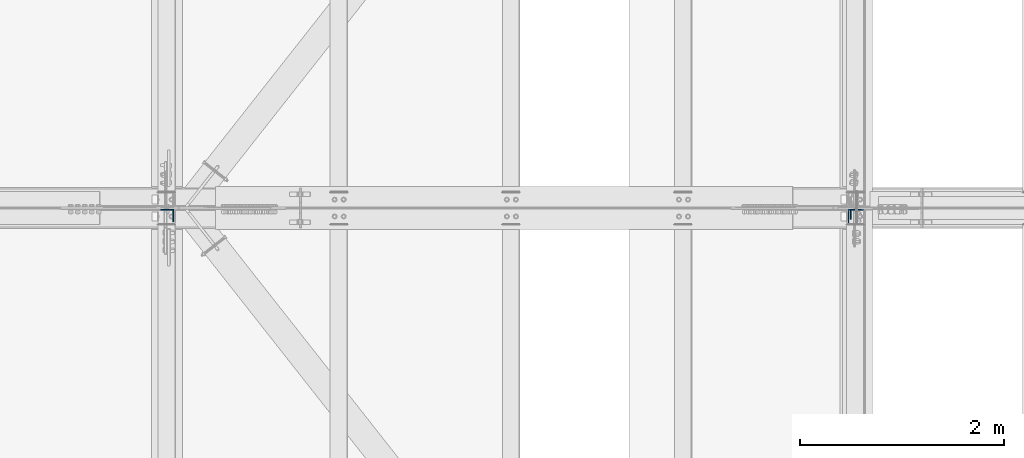
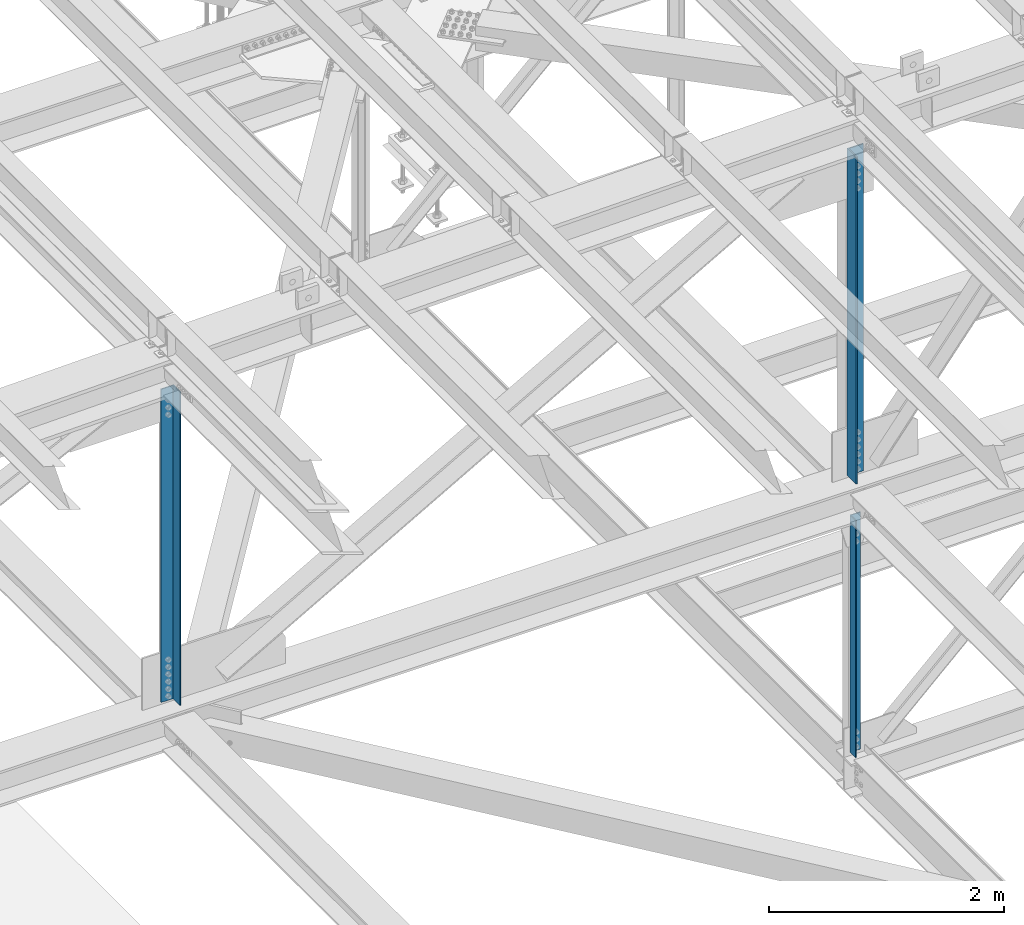
# One storey, part 1375 of 3843: 3 columns, 3 elements without a shape of their own.
"""IFC2X3 building model written with IfcOpenShell, lengths in millimetres."""

from ifc_helpers import new_model, si_unit, frame, origin_with_axes, place, context, subcontext, project, spatial, faceted_brep, material, type_object, element, aggregate, save


model = new_model("IFC2X3")

# Units and contexts
model_context = context("Model", 3, precision=1e-05, world=origin_with_axes())
body_context = subcontext(model_context, "Body", "Model", "MODEL_VIEW")
ifc_project = project(units=[si_unit("LENGTHUNIT", "METRE", prefix="MILLI"), si_unit("AREAUNIT", "SQUARE_METRE"), si_unit("VOLUMEUNIT", "CUBIC_METRE"), si_unit("MASSUNIT", "GRAM", prefix="KILO"), si_unit("TIMEUNIT", "SECOND"), si_unit("PLANEANGLEUNIT", "RADIAN"), si_unit("SOLIDANGLEUNIT", "STERADIAN"), si_unit("THERMODYNAMICTEMPERATUREUNIT", "DEGREE_CELSIUS"), si_unit("LUMINOUSINTENSITYUNIT", "LUMEN")], contexts=[model_context])

# Site, building, storey
site_placement = place(None, origin_with_axes())
site = spatial("IfcSite", under=ifc_project, at=site_placement, CompositionType="ELEMENT")
building_placement = place(site_placement, origin_with_axes())
building = spatial("IfcBuilding", under=site, at=building_placement, Name="Undefined", CompositionType="ELEMENT")
storey_placement = place(building_placement, origin_with_axes())
storey = spatial("IfcBuildingStorey", under=building, at=storey_placement, Name="Undefined", CompositionType="ELEMENT", Elevation=0.0)

# Assembly, column
assembly_1_placement = place(storey_placement, origin_with_axes())
assembly_1 = element("IfcElementAssembly", 1, at=assembly_1_placement, inside=storey, Name="ANGLE", AssemblyPlace="NOTDEFINED", PredefinedType="RIGID_FRAME")
ifc_material = material(Name="STEEL/A572-50")
column_type_1 = type_object("IfcColumnType", Name="L4X4X3/8", PredefinedType="NOTDEFINED")
column_1_placement = place(assembly_1_placement, frame((77012.8000000054, 67211.575, 39446.2000000013), z_axis=(0.0, -1.0, 0.0), x_axis=(0.0, 0.0, 1.0)))
column_1 = element("IfcColumn", 2, at=column_1_placement, type_object=column_type_1, material=ifc_material, Name="ANGLE", ObjectType="L4X4X3/8", context=body_context, shape_type="Brep", body=[
    faceted_brep([(220.046502420904, 50.8000000000029, -50.8000000000029), (220.046502420904, 50.8000000000029, 50.8000000000029), (2681.94268426253, 50.8000000000029, 50.8000000000029), (2681.94268426253, 50.8000000000029, -50.8000000000029), (220.046502420904, 41.2749999999942, 50.8000000000029), (2681.94268426253, 41.2749999999942, 50.8000000000029), (220.046502420904, 41.2749999999942, -41.2749999999942), (2681.94268426253, 41.2749999999942, -41.2749999999942), (220.046502420904, -50.8000000000029, -41.2749999999942), (2681.94268426253, -50.8000000000029, -41.2749999999942), (220.046502420904, -50.8000000000029, -50.8000000000029), (2681.94268426253, -50.8000000000029, -50.8000000000029)], [[[0, 1, 2, 3]], [[1, 4, 5, 2]], [[4, 6, 7, 5]], [[6, 8, 9, 7]], [[8, 10, 11, 9]], [[10, 0, 3, 11]], [[5, 7, 9, 11, 3, 2]], [[10, 8, 6, 4, 1, 0]]]),
])
aggregate(assembly_1, [column_1])

assembly_2_placement = place(storey_placement, origin_with_axes())
assembly_2 = element("IfcElementAssembly", 3, at=assembly_2_placement, inside=storey, Name="ANGLE", AssemblyPlace="NOTDEFINED", PredefinedType="RIGID_FRAME")
column_type_2 = type_object("IfcColumnType", Name="L6X6X1/2", PredefinedType="NOTDEFINED")
column_2_placement = place(assembly_2_placement, frame((77012.8000007684, 67186.175, 42337.7620891929), z_axis=(0.0, -1.0, 0.0), x_axis=(0.0, 0.0, 1.0)))
column_2 = element("IfcColumn", 4, at=column_2_placement, type_object=column_type_2, material=ifc_material, Name="ANGLE", ObjectType="L6X6X1/2", context=body_context, shape_type="Brep", body=[
    faceted_brep([(210.354695598835, 76.1999999999971, -76.1999999999971), (210.354695598835, 76.1999999999971, 76.1999999999971), (3607.22279320636, 76.1999999999971, 76.1999999999971), (3607.22279320636, 76.1999999999971, -76.1999999999971), (210.354695598835, 63.5, 76.1999999999971), (3607.22279320636, 63.5, 76.1999999999971), (210.354695598835, 63.5, -63.5), (3607.22279320636, 63.5, -63.5), (210.354695598835, -76.1999999999971, -63.5), (3607.22279320636, -76.1999999999971, -63.5), (210.354695598835, -76.1999999999971, -76.1999999999971), (3607.22279320636, -76.1999999999971, -76.1999999999971)], [[[0, 1, 2, 3]], [[1, 4, 5, 2]], [[4, 6, 7, 5]], [[6, 8, 9, 7]], [[8, 10, 11, 9]], [[10, 0, 3, 11]], [[5, 7, 9, 11, 3, 2]], [[10, 8, 6, 4, 1, 0]]]),
])
aggregate(assembly_2, [column_2])

assembly_3_placement = place(storey_placement, origin_with_axes())
assembly_3 = element("IfcElementAssembly", 5, at=assembly_3_placement, inside=storey, Name="ANGLE", AssemblyPlace="NOTDEFINED", PredefinedType="RIGID_FRAME")
column_type_3 = type_object("IfcColumnType", Name="L5X5X3/8", PredefinedType="NOTDEFINED")
column_3_placement = place(assembly_3_placement, frame((70256.4, 67198.875, 42344.1673578885), z_axis=(-1.0, 0.0, 0.0), x_axis=(0.0, 0.0, 1.0)))
column_3 = element("IfcColumn", 6, at=column_3_placement, type_object=column_type_3, material=ifc_material, Name="ANGLE", ObjectType="L5X5X3/8", context=body_context, shape_type="Brep", body=[
    faceted_brep([(209.637044637129, 63.5, -63.5), (209.637044637129, 63.5, 63.5), (3463.11214414293, 63.5, 63.5), (3463.11214414293, 63.5, -63.5), (209.637044637129, 53.9750000000058, 63.5), (3463.11214414293, 53.9750000000058, 63.5), (209.637044637129, 53.9750000000058, -53.9750000000058), (3463.11214414293, 53.9750000000058, -53.9750000000058), (209.637044637129, -63.5, -53.9750000000058), (3463.11214414293, -63.5, -53.9750000000058), (209.637044637129, -63.5, -63.5), (3463.11214414293, -63.5, -63.5)], [[[0, 1, 2, 3]], [[1, 4, 5, 2]], [[4, 6, 7, 5]], [[6, 8, 9, 7]], [[8, 10, 11, 9]], [[10, 0, 3, 11]], [[5, 7, 9, 11, 3, 2]], [[10, 8, 6, 4, 1, 0]]]),
])
aggregate(assembly_3, [column_3])

save(model, "model.ifc")
